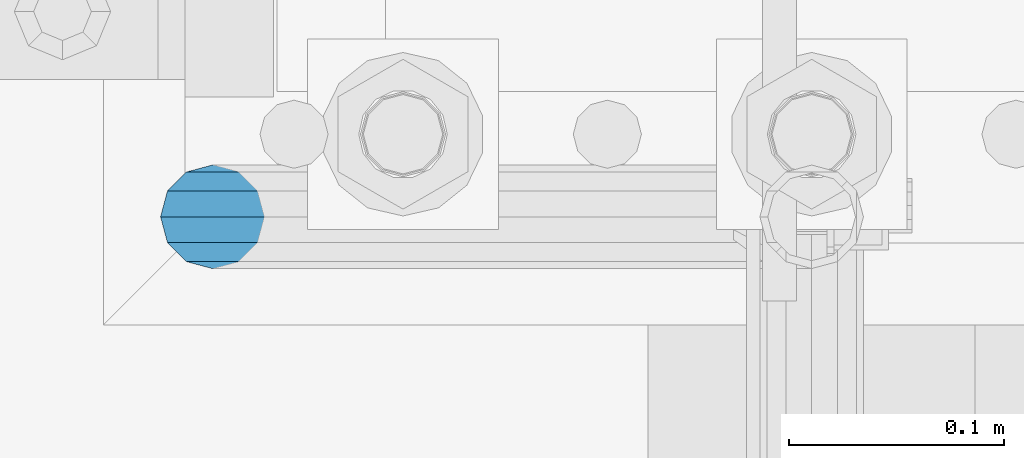
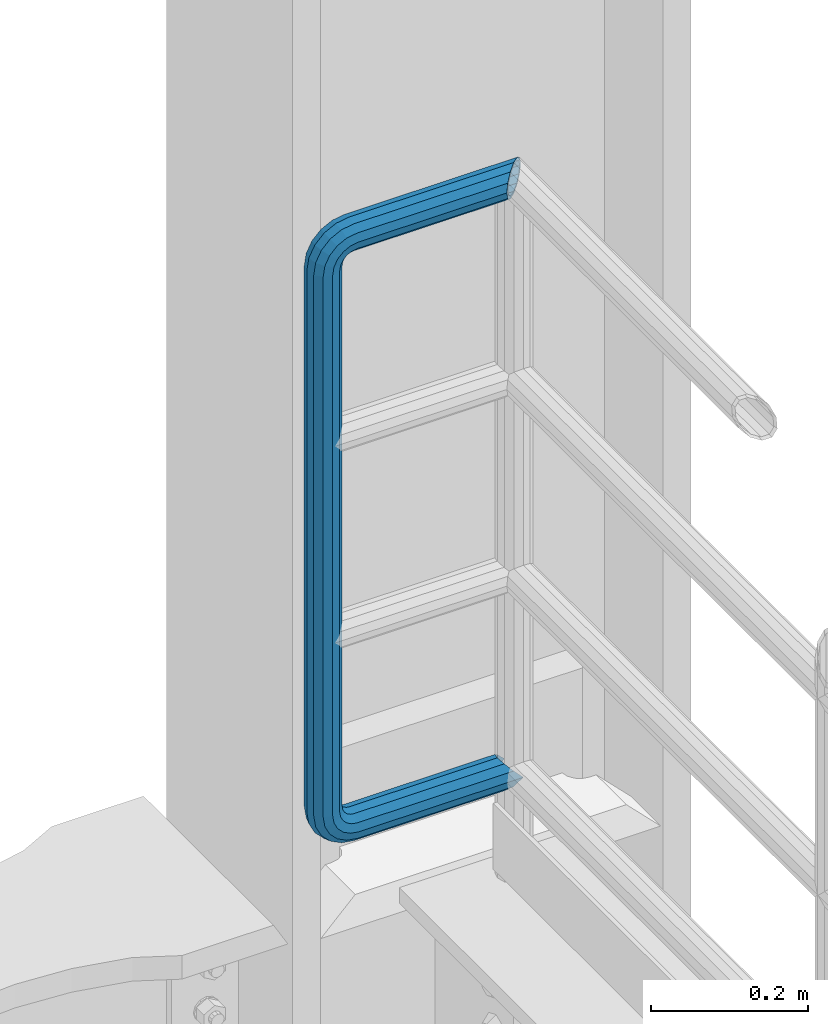
# One storey, part 1073 of 1876: 1 beam, 1 element without a shape of its own.
"""IFC2X3 building model written with IfcOpenShell, lengths in millimetres."""

from ifc_helpers import new_model, si_unit, frame, origin_with_axes, place, context, subcontext, project, spatial, faceted_brep, material, type_object, element, aggregate, save


model = new_model("IFC2X3")

# Units and contexts
model_context = context("Model", 3, precision=1e-05, world=origin_with_axes())
body_context = subcontext(model_context, "Body", "Model", "MODEL_VIEW")
ifc_project = project(units=[si_unit("LENGTHUNIT", "METRE", prefix="MILLI"), si_unit("AREAUNIT", "SQUARE_METRE"), si_unit("VOLUMEUNIT", "CUBIC_METRE"), si_unit("MASSUNIT", "GRAM", prefix="KILO"), si_unit("TIMEUNIT", "SECOND"), si_unit("PLANEANGLEUNIT", "RADIAN"), si_unit("SOLIDANGLEUNIT", "STERADIAN"), si_unit("THERMODYNAMICTEMPERATUREUNIT", "DEGREE_CELSIUS"), si_unit("LUMINOUSINTENSITYUNIT", "LUMEN")], contexts=[model_context])

# Site, building, storey
site_placement = place(None, origin_with_axes())
site = spatial("IfcSite", under=ifc_project, at=site_placement, CompositionType="ELEMENT")
building_placement = place(site_placement, origin_with_axes())
building = spatial("IfcBuilding", under=site, at=building_placement, Name="Undefined", CompositionType="ELEMENT")
storey_placement = place(building_placement, origin_with_axes())
storey = spatial("IfcBuildingStorey", under=building, at=storey_placement, Name="Undefined", CompositionType="ELEMENT", Elevation=0.0)

# Assembly, beam
assembly_placement = place(storey_placement, origin_with_axes())
assembly = element("IfcElementAssembly", 1, at=assembly_placement, inside=storey, Name="RAIL", AssemblyPlace="NOTDEFINED", PredefinedType="RIGID_FRAME")
ifc_material = material()
beam_type = type_object("IfcBeamType", Name="PIPE1-1/2SCH40", PredefinedType="NOTDEFINED")
beam_placement = place(assembly_placement, frame((7619.99999999999, 13499.7063, 9229.725), z_axis=(0.0, 0.0, 1.0), x_axis=(-1.0, 0.0, 0.0)))
beam = element("IfcBeam", 2, at=beam_placement, type_object=beam_type, material=ifc_material, Name="RAIL", ObjectType="PIPE1-1/2SCH40", context=body_context, shape_type="Brep", body=[
    faceted_brep([(1.20714750983051e-12, 24.1299999999974, -914.399963378906), (12.0650000000014, 20.8971929933159, -926.464963378905), (12.0650000000014, 20.8971929933177, -902.334963378908), (12.0650000000014, -20.8971929933195, -902.334963378908), (12.0650000000014, -20.8971929933195, -926.464963378905), (1.52133659548828e-12, -24.130000000001, -914.399963378906), (20.8971929933199, -12.0650000000023, -893.502770385589), (20.8971929933199, -12.0650000000005, -898.533841947723), (15.2545715621378, -17.7076214311819, -904.176463378906), (12.5151929933181, -20.4470000000019, -914.399963378906), (15.2545715621376, -17.7076214311819, -924.623463378906), (20.8971929933199, -12.0650000000005, -930.26608481009), (20.8971929933199, -12.0650000000023, -935.297156372224), (24.1300000000014, -1.81898940354586e-12, -934.846963378906), (24.1300000000014, -1.81898940354586e-12, -938.529963378907), (21.3906214311813, -10.2235000000019, -932.107584810088), (21.3906214311823, 10.2234999999982, -932.107584810088), (20.8971929933199, 12.0650000000005, -930.266084810086), (20.8971929933199, 12.0649999999987, -935.297156372224), (15.2545715621413, 17.7076214311783, -924.623463378906), (12.5151929933216, 20.4469999999983, -914.399963378906), (15.2545715621411, 17.7076214311783, -904.176463378906), (20.8971929933199, 12.0650000000005, -898.533841947727), (20.8971929933199, 12.0649999999987, -893.502770385589), (21.3906214311822, 10.2234999999982, -896.692341947724), (24.1300000000014, 0.0, -893.952963378906), (24.1300000000014, 0.0, -890.269963378905), (21.3906214311814, -10.2235000000019, -896.692341947724), (241.299995422363, 20.8971929933177, -12.0649999999987), (241.299995422363, 24.1299999999992, 0.0), (253.073542436527, 24.1299999999992, -1.86474665447167), (249.345252399393, 20.8971929933177, -13.3392435235728), (241.299995422363, 12.0650000000005, -20.8971929933177), (246.615954666858, 12.0650000000005, -21.7391582230448), (241.299995422363, 0.0, -24.130000000001), (245.616962362259, 0.0, -24.8137403926739), (241.299995422363, -12.0650000000005, -20.8971929933177), (246.615954666858, -12.0650000000005, -21.7391582230448), (241.299995422363, -20.8971929933177, -12.0649999999987), (249.345252399393, -20.8971929933177, -13.3392435235728), (241.299995422363, -24.1299999999992, 0.0), (253.073542436527, -24.1299999999992, -1.86474665447167), (241.299995422363, -20.8971929933177, 12.0649999999987), (256.801832473661, -20.8971929933177, 9.60975021462946), (241.299995422363, -12.0650000000005, 20.8971929933177), (259.531130206197, -12.0650000000005, 18.0096649141014), (241.299995422363, 0.0, 24.130000000001), (260.530122510796, 0.0, 21.084247083727), (241.299995422363, 12.0650000000005, 20.8971929933177), (259.531130206197, 12.0650000000005, 18.0096649141014), (241.299995422363, 20.8971929933177, 12.0649999999987), (256.801832473661, 20.8971929933177, 9.60975021462946), (291.464993896486, -20.8971929933177, -38.0999984741211), (279.399993896484, -24.1299999999992, -38.0999984741211), (279.399993896484, -24.1299999999992, -876.299964904785), (291.464993896484, -20.8971929933177, -876.299964904785), (267.334993896485, -20.8971929933177, -38.0999984741211), (267.334993896484, -20.8971929933177, -876.299964904785), (258.502800903167, -12.0650000000005, -38.0999984741211), (258.502800903166, -12.0650000000005, -876.299964904785), (255.269993896485, 0.0, -38.0999984741211), (255.269993896484, 0.0, -876.299964904785), (258.502800903167, 12.0650000000005, -38.0999984741211), (258.502800903166, 12.0650000000005, -876.299964904785), (267.334993896485, 20.8971929933177, -38.0999984741211), (267.334993896484, 20.8971929933177, -876.299964904785), (279.399993896485, 24.1299999999992, -38.0999984741211), (279.399993896484, 24.1299999999992, -876.299964904785), (291.464993896486, 20.8971929933177, -38.0999984741211), (291.464993896484, 20.8971929933177, -876.299964904785), (300.297186889804, 12.0650000000005, -38.0999984741211), (300.297186889803, 12.0650000000005, -876.299964904785), (303.529993896486, 0.0, -38.0999984741211), (303.529993896484, 0.0, -876.299964904785), (300.297186889804, -12.0650000000005, -38.0999984741211), (300.297186889803, -12.0650000000005, -876.299964904785), (297.409658810584, -12.0650000000005, -894.531099688622), (300.484240980214, 0.0, -895.53009199322), (297.409658810584, 12.0650000000005, -894.531099688622), (289.009744111112, 20.8971929933177, -891.801801956084), (277.535247242011, 24.1299999999992, -888.073511918952), (266.06075037291, 20.8971929933177, -884.345221881817), (257.660835673438, 12.0650000000005, -881.615924149282), (254.586253503809, 0.0, -880.616931844681), (257.660835673438, -12.0650000000005, -881.615924149282), (266.06075037291, -20.8971929933177, -884.345221881817), (277.535247242011, -24.130000000001, -888.073511918952), (289.009744111112, -20.8971929933195, -891.801801956084), (241.299995422363, -20.8971929933195, -902.334963378908), (241.299995422363, -12.0650000000005, -893.502770385589), (241.299995422363, -24.130000000001, -914.399963378906), (241.299995422364, -20.8971929933195, -926.464963378909), (241.299995422364, -12.0650000000005, -935.297156372228), (241.299995422364, -1.81898940354586e-12, -938.529963378911), (241.299995422364, 12.0649999999987, -935.297156372228), (241.299995422364, 20.8971929933177, -926.464963378909), (241.299995422364, 24.1299999999992, -914.39996337891), (241.299995422363, 20.8971929933177, -902.334963378908), (241.299995422363, 12.0649999999987, -893.502770385589), (241.299995422363, 0.0, -890.269963378909), (245.61696236226, 0.0, -889.586222986232), (246.615954666859, -12.0650000000005, -892.660805155861), (246.615954666859, 12.0649999999987, -892.660805155861), (249.345252399395, 20.8971929933177, -901.060719855333), (253.07354243653, 24.1299999999992, -912.535216724435), (256.801832473666, 20.8971929933177, -924.009713593536), (259.531130206202, 12.0649999999987, -932.409628293008), (260.530122510801, 0.0, -935.484210462637), (259.531130206201, -12.0650000000005, -932.409628293008), (256.801832473666, -20.8971929933195, -924.009713593536), (253.07354243653, -24.130000000001, -912.535216724435), (249.345252399395, -20.8971929933195, -901.060719855333), (251.411550782037, -12.0650000000005, -890.21732688968), (256.602983568912, -20.8971929933195, -897.362721118872), (249.511354500001, 0.0, -887.601931081743), (251.411550782037, 12.0650000000005, -890.21732688968), (256.602983568912, 20.8971929933177, -897.362721118872), (263.694612637823, 24.1299999999992, -907.123511156005), (270.786241706733, 20.8971929933177, -916.884301193139), (275.977674493594, 12.0649999999987, -924.029695422345), (277.877870775644, 0.0, -926.645091230272), (275.977674493608, -12.0650000000005, -924.029695422334), (270.786241706733, -20.8971929933195, -916.884301193139), (263.694612637823, -24.130000000001, -907.123511156005), (262.362751636451, -20.8971929933195, -891.602953051333), (272.123541673585, -24.130000000001, -898.694582120243), (255.217357407258, -12.0650000000005, -886.411520264461), (252.601961599318, 0.0, -884.511323982424), (255.217357407258, 12.0650000000005, -886.411520264461), (262.362751636451, 20.8971929933177, -891.602953051333), (272.123541673585, 24.1299999999992, -898.694582120243), (281.884331710718, 20.8971929933177, -905.786211189152), (289.029725939912, 12.0650000000005, -910.977643976028), (291.645121747852, 0.0, -912.877840258065), (289.029725939912, -12.0650000000005, -910.977643976028), (281.884331710718, -20.8971929933195, -905.786211189152), (289.009744111112, -20.8971929933177, -22.5981614228222), (297.409658810584, -12.0650000000005, -19.8688636902843), (277.535247242011, -24.1299999999992, -26.3264514599541), (266.060750372911, -20.8971929933177, -30.0547414970897), (257.660835673439, -12.0650000000005, -32.7840392296275), (254.58625350381, 0.0, -33.7830315342253), (257.660835673439, 12.0650000000005, -32.7840392296275), (266.060750372911, 20.8971929933177, -30.0547414970897), (277.535247242011, 24.1299999999992, -26.3264514599541), (289.009744111112, 20.8971929933177, -22.5981614228222), (297.409658810584, 12.0650000000005, -19.8688636902843), (300.484240980213, 0.0, -18.8698713856866), (289.029725939909, -12.0650000000005, -3.42231940287456), (291.645121747848, 0.0, -1.52212312084157), (281.884331710716, -20.8971929933177, -8.61375218975081), (272.123541673583, -24.1299999999992, -15.7053812586601), (262.362751636451, -20.8971929933177, -22.7970103275729), (255.217357407257, -12.0650000000005, -27.9884431144455), (252.601961599318, 0.0, -29.8886393964822), (255.217357407257, 12.0650000000005, -27.9884431144455), (262.362751636451, 20.8971929933177, -22.7970103275729), (272.123541673583, 24.1299999999992, -15.7053812586601), (281.884331710716, 20.8971929933177, -8.61375218975081), (289.029725939909, 12.0650000000005, -3.42231940287456), (277.877870775642, 0.0, 12.2451278513654), (275.977674493607, 12.0650000000005, 9.62973204342416), (275.977674493607, -12.0650000000005, 9.62973204342416), (270.786241706732, -20.8971929933177, 2.48433781423228), (263.694612637822, -24.1299999999992, -7.27645222290084), (256.602983568912, -20.8971929933177, -17.037242260034), (251.411550782037, -12.0650000000005, -24.1826364892258), (249.511354500002, 0.0, -26.7980322971671), (251.411550782037, 12.0650000000005, -24.1826364892258), (256.602983568912, 20.8971929933177, -17.037242260034), (263.694612637822, 24.1299999999992, -7.27645222290084), (270.786241706732, 20.8971929933177, 2.48433781423228), (24.1300000000047, 24.1299999999992, 0.0), (20.8971929933232, 20.8971929933177, 12.0649999999987), (12.0650000000041, 12.0650000000005, 20.8971929933177), (-1.45519152283669e-11, 0.0, 24.130000000001), (-12.0649999999951, -12.0650000000005, 20.8971929933177), (-20.8971929933141, -20.8971929933177, 12.0649999999987), (0.0, -24.1299999999992, 0.0), (-24.1299999999956, -24.1299999999992, 0.0), (-12.0650000000096, -20.8971929933177, -12.0649999999987), (12.0650000000064, -20.8971929933177, -12.0649999999987), (-20.8971929933141, -20.8971929933177, -12.0649999999987), (-12.0649999999951, -12.0650000000005, -20.8971929933177), (20.8971929933249, -12.0650000000005, -20.8971929933177), (-16.481093238739, -16.4810932387427, -16.4810997545756), (24.1300000000063, 0.0, -24.130000000001), (-1.45519152283669e-11, 0.0, -24.130000000001), (20.8971929933249, 12.0650000000005, -20.8971929933177), (12.0650000000041, 12.0650000000005, -20.8971929933177), (20.8971929933232, 20.8971929933177, -12.0649999999987), (16.481099754581, 16.4810997545774, -16.4810932387409), (241.299995422363, -17.7076214311801, 10.2235000000001), (241.299995422363, -20.4470000000001, 0.0), (-20.4469999999956, -20.4470000000001, 0.0), (-17.7076214311755, -17.7076214311801, 10.2235000000001), (241.299995422363, -17.7076214311801, -10.2235000000001), (-17.7076214311755, -17.7076214311801, -10.2235000000001), (241.299995422363, -10.2235000000001, -17.7076214311819), (-10.2234999999955, -10.2235000000001, -17.7076214311819), (241.299995422363, 0.0, -20.4470000000001), (-1.45519152283669e-11, 0.0, -20.4470000000001), (241.299995422363, 10.2235000000001, -17.7076214311819), (10.2235000000046, 10.2235000000001, -17.7076214311819), (241.299995422363, 17.7076214311801, -10.2235000000001), (17.7076214311846, 17.7076214311801, -10.2235000000001), (241.299995422363, 20.4470000000001, 0.0), (20.4470000000047, 20.4470000000001, 0.0), (241.299995422363, 0.0, 20.4470000000001), (241.299995422363, -10.2235000000001, 17.7076214311819), (-10.2234999999955, -10.2235000000001, 17.7076214311819), (-1.45519152283669e-11, 0.0, 20.4470000000001), (241.299995422363, 10.2235000000001, 17.7076214311819), (10.2235000000046, 10.2235000000001, 17.7076214311819), (241.299995422363, 17.7076214311801, 10.2235000000001), (17.7076214311846, 17.7076214311801, 10.2235000000001), (258.545498388721, -10.2235000000001, 14.9762020957387), (256.23277767852, -17.7076214311801, 7.85837963987069), (253.073542436527, -20.4470000000001, -1.86474665447167), (249.914307194535, -17.7076214311801, -11.5878729488177), (247.601586484334, -10.2235000000001, -18.7056954046857), (246.755071952542, 0.0, -21.31099924316), (247.601586484334, 10.2235000000001, -18.7056954046857), (249.914307194535, 17.7076214311801, -11.5878729488177), (253.073542436527, 20.4470000000001, -1.86474665447167), (256.23277767852, 17.7076214311801, 7.85837963987069), (258.545498388721, 10.2235000000001, 14.9762020957387), (259.392012920513, 0.0, 17.5815059342131), (275.713057691449, 0.0, 9.26551826108334), (274.10289136825, -10.2235000000001, 7.04931444488102), (274.10289136825, 10.2235000000001, 7.04931444488102), (269.703835164635, 17.7076214311801, 0.994533019089431), (263.694612637822, 20.4470000000001, -7.27645222290084), (257.685390111009, 17.7076214311801, -15.5474374648911), (253.286333907394, 10.2235000000001, -21.6022188906827), (251.676167584195, 0.0, -23.818422706885), (253.286333907394, -10.2235000000001, -21.6022188906827), (257.685390111009, -17.7076214311801, -15.5474374648911), (263.694612637822, -20.4470000000001, -7.27645222290084), (269.703835164635, -17.7076214311801, 0.994533019089431), (286.449308341364, -10.2235000000001, -5.29710252823133), (280.394526915574, -17.7076214311801, -9.69615873184739), (288.665512157566, 0.0, -3.68693620503473), (286.449308341364, 10.2235000000001, -5.29710252823133), (280.394526915574, 17.7076214311801, -9.69615873184739), (272.123541673583, 20.4470000000001, -15.7053812586601), (263.852556431592, 17.7076214311801, -21.7146037854764), (257.797775005802, 10.2235000000001, -26.1136599890888), (255.581571189601, 0.0, -27.723826312289), (257.797775005802, -10.2235000000001, -26.1136599890888), (263.852556431592, -17.7076214311801, -21.7146037854764), (272.123541673583, -20.4470000000001, -15.7053812586601), (287.258373536355, -17.7076214311801, -23.1672162179639), (277.535247242011, -20.4470000000001, -26.3264514599541), (294.376195992223, -10.2235000000001, -20.8544955077632), (296.981499830698, 0.0, -20.00798097597), (294.376195992223, 10.2235000000001, -20.8544955077632), (287.258373536355, 17.7076214311801, -23.1672162179639), (277.535247242011, 20.4470000000001, -26.3264514599541), (267.812120947668, 17.7076214311801, -29.485686701948), (260.6942984918, 10.2235000000001, -31.7984074121487), (258.088994653325, 0.0, -32.6449219439419), (260.6942984918, -10.2235000000001, -31.7984074121487), (267.812120947668, -17.7076214311801, -29.485686701948), (279.399993896484, -20.4470000000001, -38.0999984741211), (269.176493896485, -17.7076214311801, -38.0999984741211), (289.623493896486, -17.7076214311801, -38.0999984741211), (297.107615327666, -10.2235000000001, -38.0999984741211), (299.846993896486, 0.0, -38.0999984741211), (297.107615327666, 10.2235000000001, -38.0999984741211), (289.623493896486, 17.7076214311801, -38.0999984741211), (279.399993896485, 20.4470000000001, -38.0999984741211), (269.176493896485, 17.7076214311801, -38.0999984741211), (261.692372465305, 10.2235000000001, -38.0999984741211), (258.952993896485, 0.0, -38.0999984741211), (261.692372465305, -10.2235000000001, -38.0999984741211), (269.176493896484, -17.7076214311801, -876.299964904785), (261.692372465304, -10.2235000000001, -876.299964904785), (258.952993896484, 0.0, -876.299964904785), (261.692372465304, 10.2235000000001, -876.299964904785), (269.176493896484, 17.7076214311801, -876.299964904785), (279.399993896484, 20.4470000000001, -876.299964904785), (289.623493896484, 17.7076214311801, -876.299964904785), (297.107615327665, 10.2235000000001, -876.299964904785), (299.846993896484, 0.0, -876.299964904785), (297.107615327665, -10.2235000000001, -876.299964904785), (289.623493896484, -17.7076214311801, -876.299964904785), (279.399993896484, -20.4470000000001, -876.299964904785), (277.535247242011, -20.4470000000001, -888.073511918952), (267.812120947667, -17.7076214311801, -884.914276676958), (260.694298491799, -10.2235000000001, -882.601555966758), (258.088994653324, 0.0, -881.755041434964), (260.694298491799, 10.2235000000001, -882.601555966758), (267.812120947668, 17.7076214311801, -884.914276676958), (277.535247242011, 20.4470000000001, -888.073511918952), (287.258373536355, 17.7076214311801, -891.232747160942), (294.376195992223, 10.2235000000001, -893.545467871143), (296.981499830699, 0.0, -894.391982402936), (294.376195992223, -10.2235000000001, -893.545467871143), (287.258373536355, -17.7076214311801, -891.232747160942), (280.394526915577, -17.7076214311801, -904.703804647055), (272.123541673585, -20.4470000000001, -898.694582120243), (286.449308341367, -10.2235000000001, -909.102860850671), (288.665512157569, 0.0, -910.713027173868), (286.449308341367, 10.2235000000001, -909.102860850671), (280.394526915577, 17.7076214311801, -904.703804647055), (272.123541673585, 20.4470000000001, -898.694582120243), (263.852556431593, 17.7076214311801, -892.68535959343), (257.797775005802, 10.2235000000001, -888.286303389817), (255.581571189601, 0.0, -886.676137066617), (257.797775005802, -10.2235000000001, -888.286303389817), (263.852556431593, -17.7076214311801, -892.68535959343), (263.694612637823, -20.4470000000001, -907.123511156005), (257.685390111009, -17.7076214311801, -898.852525914015), (269.703835164636, -17.7076214311801, -915.394496397999), (274.102891368238, -10.2235000000001, -921.449277823798), (275.71305769145, 0.0, -923.66548163999), (274.102891368251, 10.2235000000001, -921.449277823787), (269.703835164636, 17.7076214311801, -915.394496397999), (263.694612637823, 20.4470000000001, -907.123511156005), (257.685390111009, 17.7076214311801, -898.852525914015), (253.286333907394, 10.2235000000001, -892.797744488227), (251.676167584195, 0.0, -890.581540672025), (253.286333907394, -10.2235000000001, -892.797744488227), (249.914307194537, -17.7076214311801, -902.812090430092), (247.601586484335, -10.2235000000001, -895.694267974224), (253.07354243653, -20.4470000000001, -912.535216724435), (256.232777678524, -17.7076214311819, -922.258343018777), (258.545498388725, -10.2235000000001, -929.376165474645), (259.392012920517, 0.0, -931.981469313119), (258.545498388725, 10.2235000000001, -929.376165474645), (256.232777678524, 17.7076214311801, -922.258343018777), (253.07354243653, 20.4470000000001, -912.535216724435), (249.914307194537, 17.7076214311801, -902.812090430092), (247.601586484335, 10.2235000000001, -895.694267974224), (246.755071952543, 0.0, -893.088964135746), (241.299995422363, -10.2235000000001, -896.692341947728), (241.299995422363, 0.0, -893.95296337891), (241.299995422363, -17.7076214311819, -904.17646337891), (241.299995422363, -20.4470000000001, -914.399963378906), (241.299995422364, -17.7076214311819, -924.62346337891), (241.299995422364, -10.2235000000001, -932.107584810088), (241.299995422364, -1.81898940354586e-12, -934.84696337891), (241.299995422364, 10.2234999999982, -932.107584810088), (241.299995422364, 17.7076214311801, -924.62346337891), (241.299995422364, 20.4470000000001, -914.39996337891), (241.299995422363, 17.7076214311801, -904.17646337891), (241.299995422363, 10.2235000000001, -896.692341947728)], [[[0, 1, 2]], [[3, 4, 5]], [[6, 7, 8, 9, 10, 11, 12, 4, 3]], [[13, 14, 12, 11, 15]], [[16, 17, 18, 14, 13]], [[2, 1, 18, 17, 19, 20, 21, 22, 23]], [[23, 22, 24, 25, 26]], [[26, 25, 27, 7, 6]], [[28, 29, 30, 31]], [[32, 28, 31, 33]], [[34, 32, 33, 35]], [[36, 34, 35, 37]], [[38, 36, 37, 39]], [[40, 38, 39, 41]], [[42, 40, 41, 43]], [[44, 42, 43, 45]], [[46, 44, 45, 47]], [[48, 46, 47, 49]], [[50, 48, 49, 51]], [[52, 53, 54, 55]], [[53, 56, 57, 54]], [[56, 58, 59, 57]], [[58, 60, 61, 59]], [[60, 62, 63, 61]], [[62, 64, 65, 63]], [[64, 66, 67, 65]], [[66, 68, 69, 67]], [[68, 70, 71, 69]], [[70, 72, 73, 71]], [[72, 74, 75, 73]], [[73, 75, 76, 77]], [[71, 73, 77, 78]], [[69, 71, 78, 79]], [[67, 69, 79, 80]], [[65, 67, 80, 81]], [[63, 65, 81, 82]], [[61, 63, 82, 83]], [[59, 61, 83, 84]], [[57, 59, 84, 85]], [[54, 57, 85, 86]], [[55, 54, 86, 87]], [[88, 89, 6, 3]], [[90, 88, 3, 5]], [[91, 90, 5, 4]], [[92, 91, 4, 12]], [[93, 92, 12, 14]], [[94, 93, 14, 18]], [[95, 94, 18, 1]], [[96, 95, 1, 0]], [[97, 96, 0, 2]], [[98, 97, 2, 23]], [[99, 98, 23, 26]], [[89, 99, 26, 6]], [[100, 99, 89, 101]], [[102, 98, 99, 100]], [[103, 97, 98, 102]], [[104, 96, 97, 103]], [[105, 95, 96, 104]], [[106, 94, 95, 105]], [[107, 93, 94, 106]], [[108, 92, 93, 107]], [[109, 91, 92, 108]], [[110, 90, 91, 109]], [[111, 88, 90, 110]], [[101, 89, 88, 111]], [[112, 101, 111, 113]], [[114, 100, 101, 112]], [[115, 102, 100, 114]], [[116, 103, 102, 115]], [[117, 104, 103, 116]], [[118, 105, 104, 117]], [[119, 106, 105, 118]], [[120, 107, 106, 119]], [[121, 108, 107, 120]], [[122, 109, 108, 121]], [[123, 110, 109, 122]], [[113, 111, 110, 123]], [[124, 113, 123, 125]], [[126, 112, 113, 124]], [[127, 114, 112, 126]], [[128, 115, 114, 127]], [[129, 116, 115, 128]], [[130, 117, 116, 129]], [[131, 118, 117, 130]], [[132, 119, 118, 131]], [[133, 120, 119, 132]], [[134, 121, 120, 133]], [[135, 122, 121, 134]], [[125, 123, 122, 135]], [[86, 125, 135, 87]], [[85, 124, 125, 86]], [[84, 126, 124, 85]], [[83, 127, 126, 84]], [[82, 128, 127, 83]], [[81, 129, 128, 82]], [[80, 130, 129, 81]], [[79, 131, 130, 80]], [[78, 132, 131, 79]], [[77, 133, 132, 78]], [[76, 134, 133, 77]], [[87, 135, 134, 76]], [[75, 55, 87, 76]], [[74, 52, 55, 75]], [[136, 52, 74, 137]], [[138, 53, 52, 136]], [[139, 56, 53, 138]], [[140, 58, 56, 139]], [[141, 60, 58, 140]], [[142, 62, 60, 141]], [[143, 64, 62, 142]], [[144, 66, 64, 143]], [[145, 68, 66, 144]], [[146, 70, 68, 145]], [[147, 72, 70, 146]], [[137, 74, 72, 147]], [[148, 137, 147, 149]], [[150, 136, 137, 148]], [[151, 138, 136, 150]], [[152, 139, 138, 151]], [[153, 140, 139, 152]], [[154, 141, 140, 153]], [[155, 142, 141, 154]], [[156, 143, 142, 155]], [[157, 144, 143, 156]], [[158, 145, 144, 157]], [[159, 146, 145, 158]], [[149, 147, 146, 159]], [[160, 149, 159, 161]], [[162, 148, 149, 160]], [[163, 150, 148, 162]], [[164, 151, 150, 163]], [[165, 152, 151, 164]], [[166, 153, 152, 165]], [[167, 154, 153, 166]], [[168, 155, 154, 167]], [[169, 156, 155, 168]], [[170, 157, 156, 169]], [[171, 158, 157, 170]], [[161, 159, 158, 171]], [[49, 161, 171, 51]], [[47, 160, 161, 49]], [[45, 162, 160, 47]], [[43, 163, 162, 45]], [[41, 164, 163, 43]], [[39, 165, 164, 41]], [[37, 166, 165, 39]], [[35, 167, 166, 37]], [[33, 168, 167, 35]], [[31, 169, 168, 33]], [[30, 170, 169, 31]], [[51, 171, 170, 30]], [[29, 50, 51, 30]], [[50, 29, 172, 173]], [[48, 50, 173, 174]], [[46, 48, 174, 175]], [[44, 46, 175, 176]], [[42, 44, 176, 177]], [[178, 40, 42, 177, 179]], [[180, 181, 38, 40, 178, 179, 182]], [[183, 184, 36, 38, 181, 180, 182, 185]], [[186, 34, 36, 184, 183, 187]], [[188, 32, 34, 186, 187, 189]], [[190, 28, 32, 188, 189, 191]], [[29, 28, 190, 172]], [[192, 193, 194, 195]], [[193, 196, 197, 194]], [[196, 198, 199, 197]], [[198, 200, 201, 199]], [[200, 202, 203, 201]], [[202, 204, 205, 203]], [[204, 206, 207, 205]], [[208, 209, 210, 211]], [[212, 208, 211, 213]], [[214, 212, 213, 215]], [[206, 214, 215, 207]], [[191, 189, 187, 183, 185, 182, 179, 177, 176, 175, 174, 173, 172, 190], [213, 211, 210, 195, 194, 197, 199, 201, 203, 205, 207, 215]], [[209, 192, 195, 210]], [[192, 209, 216, 217]], [[193, 192, 217, 218]], [[196, 193, 218, 219]], [[198, 196, 219, 220]], [[200, 198, 220, 221]], [[202, 200, 221, 222]], [[204, 202, 222, 223]], [[206, 204, 223, 224]], [[214, 206, 224, 225]], [[212, 214, 225, 226]], [[208, 212, 226, 227]], [[209, 208, 227, 216]], [[227, 228, 229, 216]], [[226, 230, 228, 227]], [[225, 231, 230, 226]], [[224, 232, 231, 225]], [[223, 233, 232, 224]], [[222, 234, 233, 223]], [[221, 235, 234, 222]], [[220, 236, 235, 221]], [[219, 237, 236, 220]], [[218, 238, 237, 219]], [[217, 239, 238, 218]], [[216, 229, 239, 217]], [[229, 240, 241, 239]], [[228, 242, 240, 229]], [[230, 243, 242, 228]], [[231, 244, 243, 230]], [[232, 245, 244, 231]], [[233, 246, 245, 232]], [[234, 247, 246, 233]], [[235, 248, 247, 234]], [[236, 249, 248, 235]], [[237, 250, 249, 236]], [[238, 251, 250, 237]], [[239, 241, 251, 238]], [[241, 252, 253, 251]], [[240, 254, 252, 241]], [[242, 255, 254, 240]], [[243, 256, 255, 242]], [[244, 257, 256, 243]], [[245, 258, 257, 244]], [[246, 259, 258, 245]], [[247, 260, 259, 246]], [[248, 261, 260, 247]], [[249, 262, 261, 248]], [[250, 263, 262, 249]], [[251, 253, 263, 250]], [[253, 264, 265, 263]], [[252, 266, 264, 253]], [[254, 267, 266, 252]], [[255, 268, 267, 254]], [[256, 269, 268, 255]], [[257, 270, 269, 256]], [[258, 271, 270, 257]], [[259, 272, 271, 258]], [[260, 273, 272, 259]], [[261, 274, 273, 260]], [[262, 275, 274, 261]], [[263, 265, 275, 262]], [[275, 265, 276, 277]], [[274, 275, 277, 278]], [[273, 274, 278, 279]], [[272, 273, 279, 280]], [[271, 272, 280, 281]], [[270, 271, 281, 282]], [[269, 270, 282, 283]], [[268, 269, 283, 284]], [[267, 268, 284, 285]], [[266, 267, 285, 286]], [[264, 266, 286, 287]], [[265, 264, 287, 276]], [[276, 287, 288, 289]], [[277, 276, 289, 290]], [[278, 277, 290, 291]], [[279, 278, 291, 292]], [[280, 279, 292, 293]], [[281, 280, 293, 294]], [[282, 281, 294, 295]], [[283, 282, 295, 296]], [[284, 283, 296, 297]], [[285, 284, 297, 298]], [[286, 285, 298, 299]], [[287, 286, 299, 288]], [[299, 300, 301, 288]], [[298, 302, 300, 299]], [[297, 303, 302, 298]], [[296, 304, 303, 297]], [[295, 305, 304, 296]], [[294, 306, 305, 295]], [[293, 307, 306, 294]], [[292, 308, 307, 293]], [[291, 309, 308, 292]], [[290, 310, 309, 291]], [[289, 311, 310, 290]], [[288, 301, 311, 289]], [[301, 312, 313, 311]], [[300, 314, 312, 301]], [[302, 315, 314, 300]], [[303, 316, 315, 302]], [[304, 317, 316, 303]], [[305, 318, 317, 304]], [[306, 319, 318, 305]], [[307, 320, 319, 306]], [[308, 321, 320, 307]], [[309, 322, 321, 308]], [[310, 323, 322, 309]], [[311, 313, 323, 310]], [[313, 324, 325, 323]], [[312, 326, 324, 313]], [[314, 327, 326, 312]], [[315, 328, 327, 314]], [[316, 329, 328, 315]], [[317, 330, 329, 316]], [[318, 331, 330, 317]], [[319, 332, 331, 318]], [[320, 333, 332, 319]], [[321, 334, 333, 320]], [[322, 335, 334, 321]], [[323, 325, 335, 322]], [[325, 336, 337, 335]], [[324, 338, 336, 325]], [[326, 339, 338, 324]], [[327, 340, 339, 326]], [[328, 341, 340, 327]], [[329, 342, 341, 328]], [[330, 343, 342, 329]], [[331, 344, 343, 330]], [[332, 345, 344, 331]], [[333, 346, 345, 332]], [[334, 347, 346, 333]], [[335, 337, 347, 334]], [[347, 337, 25, 24]], [[21, 346, 347, 24, 22]], [[345, 346, 21, 20]], [[344, 345, 20, 19]], [[343, 344, 19, 17, 16]], [[342, 343, 16, 13]], [[341, 342, 13, 15]], [[10, 340, 341, 15, 11]], [[339, 340, 10, 9]], [[338, 339, 9, 8]], [[336, 338, 8, 7, 27]], [[337, 336, 27, 25]]]),
])
aggregate(assembly, [beam])

save(model, "model.ifc")
